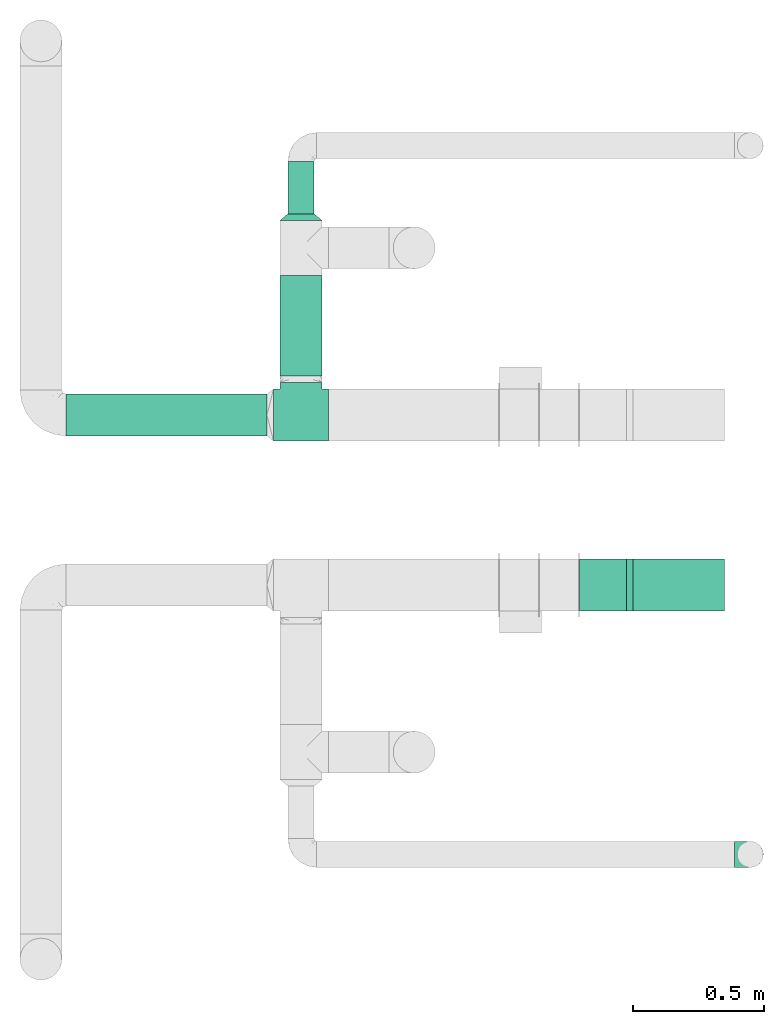
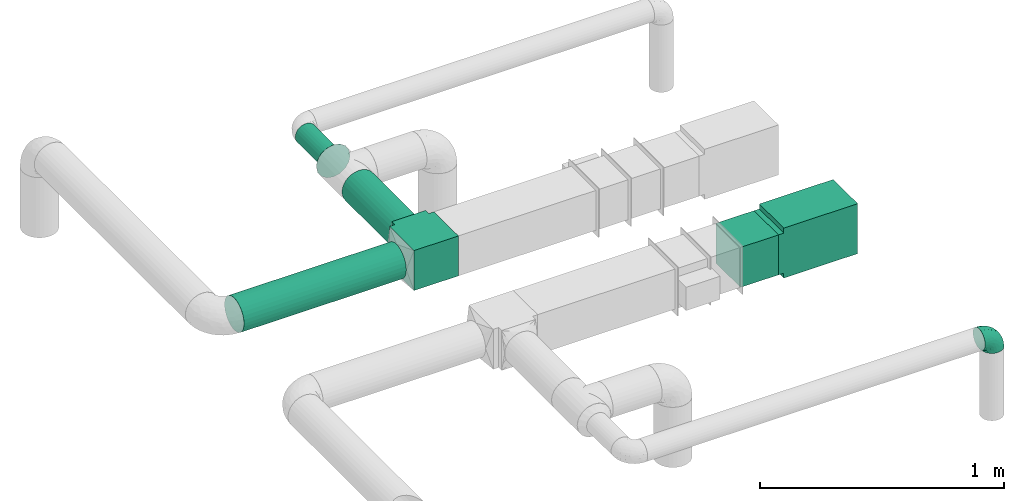
# One storey, part 6 of 12: 4 flow fittings, 4 flow segments.
"""IFC2X3 building model written with IfcOpenShell, lengths in millimetres."""

import ifcopenshell
import ifcopenshell.guid

model = None  # the IFC model being written
_history = None  # IfcOwnerHistory: only IFC2X3 demands one
_inside = {}  # id of a spatial element -> (the spatial element, [elements in it])
_under = {}  # id of a project, library or spatial element -> (it, [spatial elements below it])
_declared = {}  # id of a project -> (the project, [libraries it declares])
_typed = {}  # id of a type object -> (the type object, [elements of that type])
_made_of = {}  # id of a material, layer set ... -> (it, [elements and type objects made of it])


def new_model(schema):
    """Start an empty IFC model of exactly this schema.

    Asked for "IFC4X3", IfcOpenShell would pick the latest addendum, in which some entities
    have other attributes; the version numbers below select the first issue.
    IFC2X3 requires an IfcOwnerHistory on every rooted entity: one is made here for all.
    """
    global model, _history
    if schema == "IFC4X3":
        model = ifcopenshell.file(schema_version=(4, 3, 0, 0))
    else:
        model = ifcopenshell.file(schema=schema)
    _inside.clear()
    _under.clear()
    _declared.clear()
    _typed.clear()
    _made_of.clear()
    _history = None
    if model.schema == "IFC2X3":
        org = make("IfcOrganization", Name="unknown")
        user = make(
            "IfcPersonAndOrganization",
            ThePerson=make("IfcPerson", FamilyName="unknown"),
            TheOrganization=org,
        )
        app = make(
            "IfcApplication",
            ApplicationDeveloper=org,
            Version="unknown",
            ApplicationFullName="unknown",
            ApplicationIdentifier="unknown",
        )
        _history = make(
            "IfcOwnerHistory",
            OwningUser=user,
            OwningApplication=app,
            ChangeAction="ADDED",
            CreationDate=0,
        )
    return model


def make(cls, **values):
    """One entity of the class cls with the attributes given. An attribute that is None is left unset."""
    return model.create_entity(
        cls, **{name: value for name, value in values.items() if value is not None}
    )


def entity(cls, *values):
    """Any entity or typed value of the class cls, its attributes in the order of the schema. None: left unset."""
    e = model.create_entity(cls)
    for i, value in enumerate(values):
        if value is not None:
            e[i] = value
    return e


def rooted(cls, **values):
    """An entity with a GlobalId (a new one), such as an element, a storey or a relation."""
    return make(cls, GlobalId=ifcopenshell.guid.new(), OwnerHistory=_history, **values)


def si_unit(unit_type, name, prefix=None):
    """IfcSIUnit, for example si_unit("LENGTHUNIT", "METRE", prefix="MILLI")."""
    return make("IfcSIUnit", UnitType=unit_type, Prefix=prefix, Name=name)


def converted_unit(unit_type, name, factor, base, dimensions=None, offset=None):
    """IfcConversionBasedUnit, such as the inch: factor (a typed value) times the base unit."""
    return make(
        "IfcConversionBasedUnit"
        if offset is None
        else "IfcConversionBasedUnitWithOffset",
        ConversionOffset=offset,
        Dimensions=None
        if dimensions is None
        else entity("IfcDimensionalExponents", *dimensions),
        UnitType=unit_type,
        Name=name,
        ConversionFactor=make(
            "IfcMeasureWithUnit", ValueComponent=factor, UnitComponent=base
        ),
    )


def derived_unit(unit_type, elements):
    """IfcDerivedUnit: a product of units, each with its exponent."""
    return make(
        "IfcDerivedUnit",
        Elements=[
            make("IfcDerivedUnitElement", Unit=unit, Exponent=power)
            for unit, power in elements
        ],
        UnitType=unit_type,
    )


def assignment(units):
    """IfcUnitAssignment: the units of a project."""
    return None if units is None else make("IfcUnitAssignment", Units=units)


def point(xyz):
    """IfcCartesianPoint."""
    return None if xyz is None else make("IfcCartesianPoint", Coordinates=xyz)


def direction(xyz):
    """IfcDirection."""
    return None if xyz is None else make("IfcDirection", DirectionRatios=xyz)


def frame(location, z_axis=None, x_axis=None):
    """IfcAxis2Placement3D, a coordinate frame: its origin and axes. An axis left out is left unset."""
    return make(
        "IfcAxis2Placement3D",
        Location=point(location),
        Axis=direction(z_axis),
        RefDirection=direction(x_axis),
    )


def frame_2d(location, x_axis=None):
    """IfcAxis2Placement2D, a coordinate frame in the plane: its origin and x axis."""
    return make(
        "IfcAxis2Placement2D", Location=point(location), RefDirection=direction(x_axis)
    )


def origin():
    """The frame at (0, 0, 0) with its axes left unset."""
    return frame((0.0, 0.0, 0.0))


def origin_2d_with_axis():
    """The frame at (0, 0) in the plane with the x axis (1, 0) written out."""
    return frame_2d((0.0, 0.0), x_axis=(1.0, 0.0))


def place(relative_to, where):
    """IfcLocalPlacement: puts the frame where relative to a parent placement (None: the world)."""
    return make(
        "IfcLocalPlacement", PlacementRelTo=relative_to, RelativePlacement=where
    )


def context(
    kind, dimensions, precision=None, world=None, true_north=None, identifier=None
):
    """IfcGeometricRepresentationContext, for example the 3D "Model" context."""
    return make(
        "IfcGeometricRepresentationContext",
        ContextIdentifier=identifier,
        ContextType=kind,
        CoordinateSpaceDimension=dimensions,
        Precision=precision,
        WorldCoordinateSystem=world,
        TrueNorth=true_north,
    )


def subcontext(parent, identifier, kind, view, scale=None):
    """IfcGeometricRepresentationSubContext, for example "Body" below "Model"."""
    return make(
        "IfcGeometricRepresentationSubContext",
        ContextIdentifier=identifier,
        ContextType=kind,
        ParentContext=parent,
        TargetScale=scale,
        TargetView=view,
    )


def project(units=None, contexts=None):
    """IfcProject with its units and contexts."""
    return rooted(
        "IfcProject",
        Name="project",
        RepresentationContexts=contexts,
        UnitsInContext=assignment(units),
    )


def spatial(cls, under=None, at=None, **own):
    """A site, building, storey or space (cls), placed at a placement, below another one or the project."""
    s = rooted(cls, ObjectPlacement=at, **own)
    if under is not None:
        _under.setdefault(under.id(), (under, []))[1].append(s)
    return s


def polyline(points):
    """IfcPolyline through the points."""
    return make("IfcPolyline", Points=[point(p) for p in points])


def profile(cls, at=None, kind="AREA", **sizes):
    """A parametric profile (cls). Its sizes go by their IFC names, for example OverallWidth=200.0."""
    return make(cls, ProfileType=kind, Position=at, **sizes)


def rectangle(**sizes):
    """IfcRectangleProfileDef."""
    return profile("IfcRectangleProfileDef", **sizes)


def circle(**sizes):
    """IfcCircleProfileDef."""
    return profile("IfcCircleProfileDef", **sizes)


def outline(outer, holes=None, kind="AREA"):
    """IfcArbitraryClosedProfileDef: a profile drawn as a closed curve; with holes, ...WithVoids."""
    if holes is None:
        return make("IfcArbitraryClosedProfileDef", ProfileType=kind, OuterCurve=outer)
    return make(
        "IfcArbitraryProfileDefWithVoids",
        ProfileType=kind,
        OuterCurve=outer,
        InnerCurves=holes,
    )


def extrude(swept, where, along, depth):
    """IfcExtrudedAreaSolid: the profile swept, set in the frame where, extruded along a direction by depth."""
    return make(
        "IfcExtrudedAreaSolid",
        SweptArea=swept,
        Position=where,
        ExtrudedDirection=direction(along),
        Depth=depth,
    )


def faces_of(points, faces, orient=None, outer=None):
    """IfcFace entities. A face is a list of loops; a loop is a list of indices into points, from 0.

    orient and outer hold one flag for each loop. By default every Orientation is true, the
    first loop of a face is its IfcFaceOuterBound and the others are IfcFaceBound.
    """
    made = []
    for i, loops in enumerate(faces):
        bounds = []
        for j, loop in enumerate(loops):
            is_outer = j == 0 if outer is None else outer[i][j]
            bounds.append(
                make(
                    "IfcFaceOuterBound" if is_outer else "IfcFaceBound",
                    Bound=make("IfcPolyLoop", Polygon=[points[k] for k in loop]),
                    Orientation=True if orient is None else orient[i][j],
                )
            )
        made.append(make("IfcFace", Bounds=bounds))
    return made


def faceted_brep(points, faces, orient=None, outer=None, voids=None):
    """IfcFacetedBrep: a solid bounded by flat faces; with voids (closed shells), ...WithVoids."""
    shared = [point(p) for p in points]
    hull = make("IfcClosedShell", CfsFaces=faces_of(shared, faces, orient, outer))
    if voids is None:
        return make("IfcFacetedBrep", Outer=hull)
    return make(
        "IfcFacetedBrepWithVoids",
        Outer=hull,
        Voids=[
            make(cls, CfsFaces=faces_of(shared, fs, o, b)) for cls, fs, o, b in voids
        ],
    )


def shape(context_of_items, identifier, shape_type, items):
    """IfcShapeRepresentation: the items that make up one representation, for example the "Body"."""
    return make(
        "IfcShapeRepresentation",
        ContextOfItems=context_of_items,
        RepresentationIdentifier=identifier,
        RepresentationType=shape_type,
        Items=items,
    )


def source(mapping_origin, context_of_items, identifier, shape_type, items):
    """IfcRepresentationMap: a shape defined once, which mapped items show again and again."""
    return make(
        "IfcRepresentationMap",
        MappingOrigin=mapping_origin,
        MappedRepresentation=shape(context_of_items, identifier, shape_type, items),
    )


def transform(
    local_origin,
    x_axis=None,
    y_axis=None,
    z_axis=None,
    scale=None,
    scale2=None,
    scale3=None,
    uniform=True,
):
    """IfcCartesianTransformationOperator3D, or its non-uniform kind. x_axis, y_axis, z_axis: its Axis1, 2, 3."""
    if uniform:
        return make(
            "IfcCartesianTransformationOperator3D",
            Axis1=direction(x_axis),
            Axis2=direction(y_axis),
            LocalOrigin=point(local_origin),
            Scale=scale,
            Axis3=direction(z_axis),
        )
    return make(
        "IfcCartesianTransformationOperator3DnonUniform",
        Axis1=direction(x_axis),
        Axis2=direction(y_axis),
        LocalOrigin=point(local_origin),
        Scale=scale,
        Axis3=direction(z_axis),
        Scale2=scale2,
        Scale3=scale3,
    )


def mapped(mapping_source, mapping_target):
    """IfcMappedItem: shows the shape of a source again, moved by a transform."""
    return make(
        "IfcMappedItem", MappingSource=mapping_source, MappingTarget=mapping_target
    )


def material(Name=None, Category=None):
    """IfcMaterial."""
    return make("IfcMaterial", Name=Name, Category=Category)


def made_of(thing, what):
    """Note that an element or type object is made of a material, layer set ...; save() writes the relation."""
    if what is not None:
        _made_of.setdefault(what.id(), (what, []))[1].append(thing)
    return thing


def type_object(cls, material=None, **own):
    """A type object (cls), such as IfcWallType, which elements share."""
    return made_of(rooted(cls, **own), material)


def type_shapes(of_type, sources):
    """Give a type object the sources (RepresentationMaps) that its elements show as mapped items."""
    of_type.RepresentationMaps = sources


def element(
    cls,
    number,
    at=None,
    inside=None,
    cuts=None,
    type_object=None,
    material=None,
    context=None,
    identifier="Body",
    shape_type=None,
    held_by="IfcProductDefinitionShape",
    body=None,
    shapes=None,
    **own,
):
    """One element of the class cls, such as IfcWall. Its Tag is "e" and its number.

    at: its placement. inside: the storey or other place that contains it. cuts: it is an
    opening in that element (IfcRelVoidsElement). A single representation is given by context,
    identifier, shape_type and body (its items); several are given by shapes. held_by: the class
    of the entity that holds the representations. save() writes the other relations.
    """
    e = rooted(cls, Tag="e%d" % number, ObjectPlacement=at, **own)
    if body is not None:
        shapes = [shape(context, identifier, shape_type, body)]
    if shapes is not None:
        e.Representation = make(held_by, Representations=shapes)
    if inside is not None:
        _inside.setdefault(inside.id(), (inside, []))[1].append(e)
    if cuts is not None:
        rooted(
            "IfcRelVoidsElement", RelatingBuildingElement=cuts, RelatedOpeningElement=e
        )
    if type_object is not None:
        _typed.setdefault(type_object.id(), (type_object, []))[1].append(e)
    return made_of(e, material)


def aggregate(whole, parts):
    """IfcRelAggregates: a whole, such as a stair, and the parts it consists of."""
    return rooted("IfcRelAggregates", RelatingObject=whole, RelatedObjects=parts)


def save(model, path):
    """Write the relations noted so far, then the file.

    IfcRelAggregates (storeys below a building ...), IfcRelContainedInSpatialStructure (elements
    in a storey), IfcRelDefinesByType, IfcRelAssociatesMaterial and IfcRelDeclares: one each for
    every whole, place, type object, material and project.
    """
    for whole, parts in _under.values():
        aggregate(whole, parts)
    for where, things in _inside.values():
        rooted(
            "IfcRelContainedInSpatialStructure",
            RelatedElements=things,
            RelatingStructure=where,
        )
    for kind, things in _typed.values():
        rooted("IfcRelDefinesByType", RelatedObjects=things, RelatingType=kind)
    for what, things in _made_of.values():
        rooted("IfcRelAssociatesMaterial", RelatedObjects=things, RelatingMaterial=what)
    for by, libraries in _declared.values():
        rooted("IfcRelDeclares", RelatingContext=by, RelatedDefinitions=libraries)
    model.write(path)


model = new_model("IFC2X3")

# Units and contexts
model_context = context("Model", 3, precision=0.01, world=origin(), true_north=direction((6.12303176911189e-17, 1.0)))
body_context = subcontext(model_context, "Body", "Model", "MODEL_VIEW")
ifc_project = project(units=[si_unit("LENGTHUNIT", "METRE", prefix="MILLI"), si_unit("AREAUNIT", "SQUARE_METRE"), si_unit("VOLUMEUNIT", "CUBIC_METRE"), converted_unit("PLANEANGLEUNIT", "DEGREE", entity("IfcRatioMeasure", 0.0174532925199433), si_unit("PLANEANGLEUNIT", "RADIAN"), dimensions=[0, 0, 0, 0, 0, 0, 0]), si_unit("MASSUNIT", "GRAM", prefix="KILO"), derived_unit("MASSDENSITYUNIT", [(si_unit("MASSUNIT", "GRAM", prefix="KILO"), 1), (si_unit("LENGTHUNIT", "METRE"), -3)]), si_unit("TIMEUNIT", "SECOND"), si_unit("FREQUENCYUNIT", "HERTZ"), si_unit("THERMODYNAMICTEMPERATUREUNIT", "DEGREE_CELSIUS"), derived_unit("THERMALTRANSMITTANCEUNIT", [(si_unit("MASSUNIT", "GRAM", prefix="KILO"), 1), (si_unit("THERMODYNAMICTEMPERATUREUNIT", "KELVIN"), -1), (si_unit("TIMEUNIT", "SECOND"), -3)]), derived_unit("VOLUMETRICFLOWRATEUNIT", [(si_unit("LENGTHUNIT", "METRE"), 3), (si_unit("TIMEUNIT", "SECOND"), -1)]), si_unit("ELECTRICCURRENTUNIT", "AMPERE"), si_unit("ELECTRICVOLTAGEUNIT", "VOLT"), si_unit("POWERUNIT", "WATT"), si_unit("FORCEUNIT", "NEWTON", prefix="KILO"), si_unit("ILLUMINANCEUNIT", "LUX"), si_unit("LUMINOUSFLUXUNIT", "LUMEN"), si_unit("LUMINOUSINTENSITYUNIT", "CANDELA"), derived_unit("USERDEFINED", [(si_unit("MASSUNIT", "GRAM", prefix="KILO"), -1), (si_unit("LENGTHUNIT", "METRE"), -2), (si_unit("TIMEUNIT", "SECOND"), 3), (si_unit("LUMINOUSFLUXUNIT", "LUMEN"), 1)]), derived_unit("LINEARVELOCITYUNIT", [(si_unit("LENGTHUNIT", "METRE"), 1), (si_unit("TIMEUNIT", "SECOND"), -1)]), si_unit("PRESSUREUNIT", "PASCAL"), derived_unit("USERDEFINED", [(si_unit("LENGTHUNIT", "METRE"), -2), (si_unit("MASSUNIT", "GRAM", prefix="KILO"), 1), (si_unit("TIMEUNIT", "SECOND"), -2)])], contexts=[model_context])

# Site, building, storey
site_placement = place(None, origin())
site = spatial("IfcSite", under=ifc_project, at=site_placement, CompositionType="ELEMENT")
building_placement = place(site_placement, origin())
building = spatial("IfcBuilding", under=site, at=building_placement, CompositionType="ELEMENT")
storey_placement = place(building_placement, frame((0.0, 0.0, 8000.0)))
storey = spatial("IfcBuildingStorey", under=building, at=storey_placement, Name="02 Level", CompositionType="ELEMENT", Elevation=8000.0)

# Flow segments
duct_segment_type_1 = type_object("IfcDuctSegmentType", Name="Round Duct:Air", PredefinedType="NOTDEFINED")
flow_segment_1_placement = place(storey_placement, frame((22287.748982204, -68588.0392131986, 2918.40472776409)))
element("IfcFlowSegment", 1, at=flow_segment_1_placement, inside=storey, type_object=duct_segment_type_1, Name="Round Duct:Air", ObjectType="Round Duct:Air", context=body_context, shape_type="SweptSolid", body=[
    extrude(circle(Radius=80.0, at=origin_2d_with_axis()), frame((0.0, 81.5952722359237, 81.595272235915), z_axis=(1.0, 0.0, 0.0), x_axis=(0.0, -1.0, 0.0)), (0.0, 0.0, 1.0), 768.241088647822),
])
flow_segment_2_placement = place(storey_placement, frame((23134.3947986159, -67737.2449387878, 2948.40472776403)))
element("IfcFlowSegment", 2, at=flow_segment_2_placement, inside=storey, type_object=duct_segment_type_1, Name="Round Duct:Air", ObjectType="Round Duct:Air", context=body_context, shape_type="SweptSolid", body=[
    extrude(circle(Radius=50.0, at=origin_2d_with_axis()), frame((51.5952722359175, 0.0, 51.5952722359154), z_axis=(0.0, 1.0, 0.0), x_axis=(-1.0, 0.0, 0.0)), (0.0, 0.0, 1.0), 200.701380999497),
])
flow_segment_3_placement = place(storey_placement, frame((23104.3947986159, -68356.4439409626, 2918.40472776409)))
element("IfcFlowSegment", 3, at=flow_segment_3_placement, inside=storey, type_object=duct_segment_type_1, Name="Round Duct:Air", ObjectType="Round Duct:Air", context=body_context, shape_type="SweptSolid", body=[
    extrude(circle(Radius=80.0, at=origin_2d_with_axis()), frame((81.595272235915, 0.0, 81.5952722359129), z_axis=(0.0, 1.0, 0.0), x_axis=(-1.0, 0.0, 0.0)), (0.0, 0.0, 1.0), 384.199002174792),
])

# Flow fitting
duct_fitting_type_1 = type_object("IfcDuctFittingType", Name="Air_Elbow short_Circ", PredefinedType="NOTDEFINED")
shared_shape_1 = source(origin(), body_context, "Body", "Brep", [
    faceted_brep([(-60.0, 0.0, -50.0), (-60.0, -12.9409522551259, -48.2962913144534), (-60.0, -25.0, -43.3012701892219), (-60.0, -35.3553390593273, -35.3553390593274), (-60.0, -43.3012701892218, -25.0), (-60.0, -48.2962913144533, -12.9409522551262), (-60.0, -50.0, 0.0), (-60.0, -48.2962913144534, 12.9409522551259), (-60.0, -43.301270189222, 25.0), (-60.0, -35.3553390593275, 35.3553390593272), (-60.0, -25.0, 43.3012701892218), (-60.0, -12.9409522551262, 48.2962913144533), (-60.0, 0.0, 50.0), (-60.0, 12.9409522551258, 48.2962913144534), (-60.0, 18.9704761275628, 45.7987807518377), (-60.0, 25.0, 43.301270189222), (-60.0, 35.3553390593271, 35.3553390593275), (-60.0, 43.3012701892217, 25.0), (-60.0, 48.2962913144533, 12.9409522551263), (-60.0, 50.0, 0.0), (-60.0, 48.2962913144534, -12.940952255126), (-60.0, 43.3012701892219, -25.0), (-60.0, 35.3553390593274, -35.3553390593273), (-60.0, 25.0, -43.3012701892219), (-60.0, 12.9409522551261, -48.2962913144533), (-12.9409522551252, 60.0, -48.2962913144533), (-18.9704761275622, 60.0, -45.7987807518376), (-25.0, 60.0, -43.3012701892219), (-35.3553390593265, 60.0, -35.3553390593273), (-43.301270189221, 60.0, -25.0), (-48.2962913144525, 60.0, -12.940952255126), (-50.0, 60.0, 0.0), (-48.2962913144524, 60.0, 12.9409522551263), (-43.3012701892209, 60.0, 25.0), (-35.3553390593263, 60.0, 35.3553390593275), (-25.0, 60.0, 43.301270189222), (-12.9409522551249, 60.0, 48.2962913144534), (0.0, 60.0, 50.0), (12.9409522551271, 60.0, 48.2962913144533), (25.0, 60.0, 43.3012701892218), (35.3553390593284, 60.0, 35.3553390593272), (43.3012701892229, 60.0, 25.0), (48.2962913144543, 60.0, 12.9409522551259), (50.0, 60.0, 0.0), (48.2962913144542, 60.0, -12.9409522551262), (43.3012701892227, 60.0, -25.0), (35.3553390593281, 60.0, -35.3553390593274), (25.0, 60.0, -43.3012701892219), (12.9409522551268, 60.0, -48.2962913144534), (0.0, 60.0, -50.0), (-49.0564079906538, -40.7801415025898, 28.076858272246), (-41.7413930879589, -46.3367006663211, 14.3622192349088), (-34.4613055182162, -40.2781615499549, 24.6893391361235), (-43.0040653093767, -47.3081083962334, 0.0), (-49.945230570524, 14.009456366224, 48.3010541644054), (-46.9531334224505, 28.9691372331723, 42.5007483631415), (46.3367008388525, 41.7413924405609, 14.3622183025403), (-20.8886043148544, -37.032907476011, 22.5646988156665), (-16.4026032888538, -28.8335615486346, 31.3447155376829), (-28.9195822317624, -34.3595042325614, 30.8522337271345), (18.1051423029501, 18.6630708487668, 41.1725129713058), (21.5851347328685, 39.3600400603544, 43.7780030266717), (8.51327307359233, 29.8490270681828, 47.7425705251578), (-16.993357552601, 43.112835299455, 48.0588376259554), (-3.94145017646366, 44.1513377558611, 49.9695692624666), (-39.360041631582, -21.585137213725, 43.7780019122438), (-18.6630773197735, -18.1051465687322, 41.1725124591201), (-29.8490305613342, -8.51327565171467, 47.7425702287428), (-41.9572959526986, -32.3456520264411, 36.575294220854), (-28.3738768436699, -26.9110252548877, 38.0083212356069), (-51.9080682539527, 51.9080682564403, 11.9284381035673), (-47.8035915916317, 49.3365848090307, 24.1167211667097), (-28.9388870718402, 47.4392187660381, 42.4028289139121), (-46.4119732313288, -8.97786791845547, 48.9268647037242), (-0.0901680697707372, -16.249793899354, 33.6631038709893), (12.7026747916207, -16.0653579926251, 21.330563165355), (15.3655862372502, -1.44443599762982, 33.3656926605527), (-40.3512409746586, 17.2001159603688, 48.3058104561749), (-43.5357165770215, 3.92607608695299, 49.9756911723036), (-26.0984306641832, 9.4519602521943, 49.9925353018775), (-51.5116032222349, 38.9116886125261, 33.3337470302399), (32.3456522233896, 41.9572963751397, 36.5752941161915), (34.3595052098631, 28.9195768148052, 30.852230382061), (40.2781623134548, 34.4613024546835, 24.689336501659), (-52.6192947824697, 44.3162483434043, 26.0687788699409), (8.97786691245749, 46.4119718726044, 48.9268648562795), (35.0507691245895, 17.8379542600364, 23.7817320689175), (-10.9191638901366, -35.9593562872322, 14.7243484546897), (0.164802122834046, -30.9507973718637, 9.70158150296541), (-0.154113830211583, -27.0441585303382, 20.4371969134619), (40.7801421145919, 49.0564069362065, 28.0768572079665), (42.5446020921407, 25.3772134428819, 13.1791087429088), (10.303795037543, -23.1674391280597, 10.425151792526), (23.1044280783399, -10.2139010010231, 10.911201952746), (44.6162167924678, 26.008130618756, 0.0), (47.3081083962343, 43.0040653093781, 0.0), (-41.6246972537655, 41.624696659769, 36.6481760707585), (-32.7984308187714, 33.1644722725009, 45.0025999357929), (-7.74597844975689, 15.8760781607658, 49.2907901610601), (-16.0198594588589, 0.790040969679908, 48.0702532559686), (-10.2505184648613, 32.0701285913551, 49.9130990257927), (-52.9289321881336, 52.9289321881345, 0.0), (-38.9116885130941, 51.5116028691678, 33.3337472807585), (28.8335585354312, 16.4025932897411, 31.3447134244473), (27.3373523634918, 28.9262874076833, 37.8242669720924), (-10.6758764332908, -36.8040430868554, 0.0), (-21.0820556464647, 25.013405385062, 49.4085637061446), (-25.3772163464242, -42.5446022063287, 13.179111746218), (-29.4708300504911, 18.1716321771538, 49.3204506255928), (-0.613576836584022, 32.0726800049485, 49.6825501479137), (-26.0081306187546, -44.6162167924668, 0.0), (7.809323786389, 12.5506490133832, 44.518448707346), (-1.21981718883359, 1.21981162112378, 44.3295369128094), (4.65637775217312, -28.991869381244, 0.0), (25.4694098156993, -0.899564345657441, 21.9045256717261), (30.9271083665945, -0.192011278925337, 9.72551394481069), (36.8040430868565, 10.6758764332921, 0.0), (8.17237141004653, 0.709602060124845, 39.7363553078916), (-1.20691178924098, -8.42774890414073, 39.8368437988478), (-11.8311378719951, -8.12805454147699, 44.1670059112514), (16.8241235667092, -16.8241235667079, 0.0), (35.9593546638031, 10.9191599029529, 14.7243472530362), (28.9918693812452, -4.65637775217184, 0.0), (-14.0094588862512, 49.9452236085703, -48.3010539035587), (-41.7413926252934, -46.3367005832334, -14.3622192468898), (-34.4613048910139, -40.2781614393135, -24.6893390523416), (-25.3772156484835, -42.5446019119684, -13.1791119497906), (-43.1128355702084, 16.9933564311214, -48.0588378972243), (-44.1513388294639, 3.94144876101963, -49.969569299814), (-49.3365851024771, 47.8035917204495, -24.1167206397972), (-41.62469790636, 41.6246960630329, -36.6481760341003), (-51.5116035577561, 38.9116884747343, -33.3337470330805), (23.1674375203698, -10.3037953844737, -10.4251565011195), (10.2138986720569, -23.1044286164337, -10.9112068363266), (16.0653446591387, -12.7026862735946, -21.330566780897), (35.9593546209329, 10.9191616413996, -14.7243499458666), (30.9507965291521, -0.164803474452689, -9.70158128624016), (27.0441512446144, 0.154114142874967, -20.4372107139949), (-18.6630757642047, -18.1051470727615, -41.1725116507822), (-16.4026019873643, -28.8335613017021, -31.344715100551), (-28.9262923378956, -27.3373567288812, -37.8242648451571), (-15.8760743141415, 7.74597807562093, -49.2907896898935), (-9.45196719952168, 26.0984311316614, -49.9925354060889), (-0.79004904716724, 16.0198534732482, -48.0702540902608), (-25.0134056140136, 21.0820528609103, -49.4085640038716), (-49.0564077792961, -40.7801415002595, -28.0768582420378), (-47.4392196421628, 28.9388866268174, -42.4028289664685), (-33.1644687800828, 32.7984277324913, -45.0026021871039), (-51.9080682748156, 51.9080682458111, -11.9284380741106), (-41.9572952892088, -32.3456521258773, -36.5752940113004), (-39.3600407942016, -21.5851376014369, -43.7780015915287), (-29.8490289400598, -8.5132766456386, -47.7425697425162), (-46.411972568153, -8.97786849540185, -48.9268645575236), (-28.9195813138317, -34.3595041939927, -30.8522334076151), (-17.8379596675892, -35.0507702162708, -23.7817342784206), (21.5851368100191, 39.3600388626355, -43.7780017534797), (26.9110256448416, 28.3738769796432, -38.0083209621406), (18.1051443153088, 18.6630730295509, -41.1725124486671), (-38.911688364674, 51.5116023985273, -33.3337476311683), (-44.316248159738, 52.6192941440622, -26.0687795868405), (-17.2001201011705, 40.3512365316697, -48.3058099460363), (-3.92607321834031, 43.5357049838062, -49.9756913600445), (8.51327412363391, 29.8490256018375, -47.7425700423665), (8.97786798225732, 46.4119703958823, -48.9268645751331), (40.7801413413476, 49.0564079294803, -28.0768584987253), (-28.969136268001, 46.9531365639949, -42.5007481599507), (16.2497893015437, 0.0901603719773552, -33.6631026184802), (1.44442453081588, -15.3655954628303, -33.3656927670723), (32.3456517066656, 41.9572939682546, -36.5752941586943), (46.3367004266908, 41.7413922128929, -14.3622195286513), (34.3595039081184, 28.9195810717321, -30.8522336573022), (37.0329066484517, 20.888602858321, -22.564699256686), (28.8335602968518, 16.402602640196, -31.3447165791004), (40.2781610753798, 34.461304879185, -24.6893396682814), (-32.0701289123428, 10.2505155181949, -49.9130991682027), (42.5446013435109, 25.3772148558883, -13.1791129929581), (-18.17163862849, 29.4708285244359, -49.3204499074468), (-32.0726819537407, 0.61357350659226, -49.6825499006192), (-12.5506417422758, -7.80933382246174, -44.5184423716321), (-1.21981337419447, 1.21981084831843, -44.3295352204376), (0.899550937376629, -25.4694163362272, -21.9045307406697), (0.192009591001318, -30.9271092740971, -9.72551482732434), (-0.709596078235449, -8.17237239935393, -39.7363517396473), (8.42775025848031, 1.2069144200305, -39.8368443201002), (8.12805004108825, 11.8311369938791, -44.1670075921659), (-10.9191629014402, -35.9593557213529, -14.724348628576)], [[[0, 1, 2, 3, 4, 5, 6, 7, 8, 9, 10, 11, 12, 13, 14, 15, 16, 17, 18, 19, 20, 21, 22, 23, 24]], [[25, 26, 27, 28, 29, 30, 31, 32, 33, 34, 35, 36, 37, 38, 39, 40, 41, 42, 43, 44, 45, 46, 47, 48, 49]], [[50, 51, 52]], [[53, 7, 6]], [[54, 55, 15]], [[41, 56, 42]], [[57, 58, 59]], [[60, 61, 62]], [[36, 63, 64]], [[65, 66, 67]], [[10, 68, 65]], [[59, 69, 68]], [[70, 71, 32]], [[9, 8, 50]], [[35, 72, 63]], [[12, 11, 73]], [[74, 75, 76]], [[15, 14, 13, 54]], [[77, 78, 79]], [[11, 10, 65]], [[51, 8, 7]], [[16, 80, 17]], [[81, 82, 83]], [[80, 84, 17]], [[15, 55, 16]], [[35, 34, 72]], [[18, 70, 19]], [[65, 67, 73]], [[38, 37, 85]], [[84, 18, 17]], [[61, 38, 85]], [[82, 86, 83]], [[87, 88, 89]], [[38, 61, 39]], [[40, 90, 41]], [[64, 37, 36]], [[56, 83, 91]], [[56, 41, 90]], [[61, 81, 39]], [[92, 93, 75]], [[56, 94, 95]], [[72, 96, 97]], [[98, 79, 99]], [[100, 64, 63]], [[101, 19, 70]], [[10, 9, 68]], [[101, 70, 31]], [[65, 69, 66]], [[96, 102, 71]], [[60, 103, 104]], [[33, 102, 34]], [[88, 87, 105]], [[33, 32, 71]], [[63, 72, 97]], [[98, 106, 79]], [[36, 35, 63]], [[13, 12, 78]], [[107, 87, 57]], [[81, 40, 39]], [[83, 86, 91]], [[7, 53, 51]], [[95, 42, 56]], [[73, 78, 12]], [[108, 79, 106]], [[77, 108, 97]], [[80, 55, 96]], [[102, 72, 34]], [[96, 55, 97]], [[100, 63, 106]], [[64, 109, 85]], [[104, 81, 61]], [[90, 81, 83]], [[50, 68, 9]], [[59, 68, 52]], [[78, 67, 79]], [[110, 51, 53]], [[43, 42, 95]], [[99, 79, 67]], [[111, 98, 112]], [[100, 109, 64]], [[52, 51, 107]], [[88, 113, 92]], [[114, 93, 115]], [[103, 60, 76]], [[103, 76, 114]], [[116, 94, 91]], [[112, 117, 111]], [[76, 75, 114]], [[112, 118, 117]], [[119, 118, 112]], [[74, 66, 58]], [[99, 119, 112]], [[74, 58, 89]], [[76, 117, 118]], [[77, 97, 55]], [[63, 97, 106]], [[92, 113, 120]], [[114, 121, 86]], [[115, 93, 122]], [[122, 93, 120]], [[75, 93, 114]], [[93, 92, 120]], [[92, 75, 89]], [[74, 89, 75]], [[57, 89, 58]], [[64, 85, 37]], [[61, 85, 62]], [[65, 73, 11]], [[78, 73, 67]], [[51, 110, 107]], [[115, 116, 121]], [[91, 121, 116]], [[94, 56, 91]], [[71, 102, 33]], [[72, 102, 96]], [[55, 80, 16]], [[84, 96, 71]], [[106, 98, 100]], [[109, 98, 62]], [[98, 109, 100]], [[85, 109, 62]], [[89, 88, 92]], [[107, 105, 87]], [[96, 84, 80]], [[84, 71, 70]], [[70, 18, 84]], [[31, 70, 32]], [[51, 50, 8]], [[68, 50, 52]], [[81, 90, 40]], [[56, 90, 83]], [[54, 78, 77]], [[78, 54, 13]], [[54, 77, 55]], [[60, 104, 61]], [[82, 104, 103]], [[104, 82, 81]], [[86, 82, 103]], [[114, 86, 103]], [[86, 121, 91]], [[57, 59, 52]], [[69, 59, 58]], [[66, 69, 58]], [[68, 69, 65]], [[107, 57, 52]], [[57, 87, 89]], [[97, 108, 106]], [[77, 79, 108]], [[119, 67, 66]], [[98, 99, 112]], [[67, 119, 99]], [[118, 66, 74]], [[66, 118, 119]], [[76, 118, 74]], [[76, 60, 117]], [[111, 117, 60]], [[60, 62, 111]], [[98, 111, 62]], [[105, 107, 110]], [[113, 88, 105]], [[116, 115, 122]], [[114, 115, 121]], [[123, 27, 26, 25]], [[124, 125, 126]], [[23, 127, 24]], [[0, 24, 128]], [[129, 130, 131]], [[132, 133, 134]], [[21, 131, 22]], [[135, 136, 137]], [[21, 20, 129]], [[138, 139, 140]], [[141, 142, 143]], [[144, 142, 141]], [[124, 4, 145]], [[146, 130, 147]], [[124, 110, 53]], [[148, 129, 20]], [[149, 2, 150]], [[138, 150, 151]], [[1, 150, 2]], [[127, 146, 147]], [[23, 22, 146]], [[145, 4, 3]], [[3, 2, 149]], [[1, 152, 150]], [[153, 154, 125]], [[149, 153, 125]], [[19, 101, 148]], [[125, 154, 126]], [[31, 30, 148]], [[155, 156, 157]], [[29, 158, 159]], [[48, 47, 155]], [[136, 135, 116]], [[28, 158, 29]], [[146, 127, 23]], [[160, 161, 142]], [[155, 162, 163]], [[46, 45, 164]], [[28, 27, 165]], [[166, 134, 167]], [[48, 163, 49]], [[168, 155, 47]], [[24, 127, 128]], [[169, 45, 44]], [[170, 171, 172]], [[162, 155, 157]], [[1, 0, 152]], [[173, 164, 169]], [[25, 49, 161]], [[43, 95, 44]], [[47, 46, 168]], [[174, 128, 127]], [[170, 156, 168]], [[123, 165, 27]], [[4, 124, 5]], [[44, 95, 169]], [[148, 20, 19]], [[175, 135, 171]], [[159, 30, 29]], [[53, 5, 124]], [[163, 161, 49]], [[176, 142, 144]], [[160, 176, 147]], [[158, 165, 130]], [[131, 146, 22]], [[130, 165, 147]], [[174, 127, 144]], [[128, 177, 152]], [[140, 149, 150]], [[145, 149, 125]], [[164, 168, 46]], [[170, 168, 173]], [[161, 162, 142]], [[94, 169, 95]], [[6, 5, 53]], [[143, 142, 162]], [[178, 141, 179]], [[174, 177, 128]], [[173, 169, 175]], [[136, 122, 132]], [[180, 133, 181]], [[139, 138, 167]], [[139, 167, 180]], [[105, 110, 126]], [[179, 182, 178]], [[167, 134, 180]], [[179, 183, 182]], [[184, 183, 179]], [[166, 157, 172]], [[143, 184, 179]], [[166, 172, 137]], [[167, 182, 183]], [[160, 147, 165]], [[127, 147, 144]], [[132, 122, 120]], [[180, 185, 154]], [[181, 133, 113]], [[113, 133, 120]], [[134, 133, 180]], [[133, 132, 120]], [[132, 134, 137]], [[166, 137, 134]], [[171, 137, 172]], [[128, 152, 0]], [[150, 152, 151]], [[155, 163, 48]], [[161, 163, 162]], [[169, 94, 175]], [[181, 105, 185]], [[126, 185, 105]], [[110, 124, 126]], [[129, 131, 21]], [[146, 131, 130]], [[165, 158, 28]], [[159, 130, 129]], [[144, 141, 174]], [[177, 141, 151]], [[141, 177, 174]], [[152, 177, 151]], [[137, 136, 132]], [[175, 116, 135]], [[130, 159, 158]], [[159, 129, 148]], [[31, 148, 101]], [[148, 30, 159]], [[169, 164, 45]], [[168, 164, 173]], [[149, 145, 3]], [[124, 145, 125]], [[123, 161, 160]], [[161, 123, 25]], [[123, 160, 165]], [[138, 140, 150]], [[153, 140, 139]], [[140, 153, 149]], [[154, 153, 139]], [[180, 154, 139]], [[154, 185, 126]], [[171, 170, 173]], [[156, 170, 172]], [[157, 156, 172]], [[168, 156, 155]], [[175, 171, 173]], [[171, 135, 137]], [[147, 176, 144]], [[160, 142, 176]], [[184, 162, 157]], [[141, 143, 179]], [[162, 184, 143]], [[183, 157, 166]], [[157, 183, 184]], [[167, 183, 166]], [[167, 138, 182]], [[178, 182, 138]], [[138, 151, 178]], [[141, 178, 151]], [[116, 175, 94]], [[122, 136, 116]], [[105, 181, 113]], [[180, 181, 185]]]),
])
type_shapes(duct_fitting_type_1, [shared_shape_1])
flow_fitting_1_placement = place(storey_placement, frame((24903.4900708518, -70185.9356124915, 3000.0), z_axis=(0.0, -1.0, 0.0), x_axis=(0.0, 0.0, 1.0)))
element("IfcFlowFitting", 4, at=flow_fitting_1_placement, inside=storey, type_object=duct_fitting_type_1, Name="elbow_short_001:Air_Elbow short_Circ", ObjectType="elbow_short_001:Air_Elbow short_Circ", context=body_context, shape_type="MappedRepresentation", body=[
    mapped(shared_shape_1, transform((0.0, 0.0, 0.0), scale=1.0)),
])

# Flow segment
duct_segment_type_2 = type_object("IfcDuctSegmentType", Name="Rectangular Duct:Air", PredefinedType="NOTDEFINED")
flow_segment_4_placement = place(storey_placement, frame((24250.9900708518, -69256.0352293172, 2900.0)))
element("IfcFlowSegment", 5, at=flow_segment_4_placement, inside=storey, type_object=duct_segment_type_2, Name="Rectangular Duct:Air", ObjectType="Rectangular Duct:Air", context=body_context, shape_type="SweptSolid", body=[
    extrude(rectangle(XDim=179.671447124557, YDim=199.999999999998, at=frame_2d((0.0, -4.33431068813661e-12), x_axis=(1.0, 0.0))), frame((89.8357235622787, 100.0, 0.0)), (0.0, 0.0, 1.0), 200.000000000002),
])

# Flow fittings
duct_fitting_type_2 = type_object("IfcDuctFittingType", Name="Air_Rect", PredefinedType="NOTDEFINED")
shared_shape_2 = source(origin(), body_context, "Body", "SweptSolid", [
    extrude(outline(polyline([(-125.0, 81.25), (-125.0, -268.75), (125.0, -268.75), (125.0, 81.2500000000001), (100.0, 81.2500000000001), (100.0, 106.25), (-100.0, 106.25), (-100.0, 81.25), (-125.0, 81.25)])), frame((0.0, -93.75, -100.0), z_axis=(0.0, 0.0, -1.0), x_axis=(1.0, 0.0, 0.0)), (0.0, 0.0, -1.0), 200.0),
])
type_shapes(duct_fitting_type_2, [shared_shape_2])
flow_fitting_2_placement = place(storey_placement, frame((24630.6615179764, -69156.0352293172, 3000.0), z_axis=(0.0, -1.0, 0.0), x_axis=(0.0, 0.0, -1.0)))
element("IfcFlowFitting", 6, at=flow_fitting_2_placement, inside=storey, type_object=duct_fitting_type_2, Name="1_001:Air_Rect", ObjectType="1_001:Air_Rect", context=body_context, shape_type="MappedRepresentation", body=[
    mapped(shared_shape_2, transform((0.0, 0.0, 0.0), scale=1.0)),
])
ifc_material = material(Name="Material_Duct")
duct_fitting_type_3 = type_object("IfcDuctFittingType", Name="Air_Reduction_Circ", PredefinedType="NOTDEFINED", material=ifc_material)
shared_shape_3 = source(origin(), body_context, "Body", "Brep", [
    faceted_brep([(25.0, 45.0484433951223, -21.6941869558729), (25.0, 47.5242216975607, -10.8470934779334), (25.0, 50.0, 0.0), (25.0, 47.5242216975601, 10.8470934779448), (25.0, 45.0484433951193, 21.6941869558836), (25.0, 38.1114667440265, 30.3928805396443), (25.0, 31.1744900929338, 39.0915741234051), (25.0, 21.1502683953737, 43.9189848662489), (25.0, 11.1260466978137, 48.7463956090927), (25.0, 0.0, 48.7463956090925), (25.0, -11.1260466978156, 48.7463956090923), (25.0, -21.1502683953754, 43.9189848662482), (25.0, -31.1744900929351, 39.0915741234041), (25.0, -38.1114667440274, 30.3928805396434), (25.0, -45.0484433951197, 21.6941869558827), (25.0, -47.5242216975603, 10.8470934779443), (25.0, -50.0, 0.0), (25.0, -47.5242216975608, -10.8470934779335), (25.0, -45.0484433951224, -21.6941869558726), (25.0, -38.1114667440309, -30.3928805396354), (25.0, -31.1744900929393, -39.0915741233981), (25.0, -21.1502683953783, -43.9189848662439), (25.0, -11.1260466978174, -48.7463956090898), (25.0, 0.0, -48.7463956090899), (25.0, 11.1260466978161, -48.74639560909), (25.0, 21.1502683953773, -43.9189848662444), (25.0, 31.1744900929385, -39.0915741233988), (25.0, 38.1114667440304, -30.3928805396358), (0.0, 80.0, 0.0), (0.0, 76.9551813004531, -15.307337294604), (0.0, 73.9103626009062, -30.6146745892082), (0.0, 65.2394525479173, -43.5916085420681), (0.0, 56.5685424949284, -56.5685424949279), (0.0, 43.5916085420694, -65.2394525479189), (0.0, 30.6146745892104, -73.9103626009099), (0.0, 15.3073372946054, -76.9551813004588), (0.0, 0.0, -80.0), (0.0, -15.3073372946045, -76.9551813004584), (0.0, -30.6146745892093, -73.9103626009091), (0.0, -43.5916085420678, -65.239452547918), (0.0, -56.5685424949263, -56.568542494927), (0.0, -65.2394525479148, -43.5916085420674), (0.0, -73.9103626009034, -30.6146745892079), (0.0, -76.9551813004502, -15.3073372946042), (0.0, -80.0, 0.0), (0.0, -76.9551813004499, 15.3073372946029), (0.0, -73.9103626008998, 30.6146745892058), (0.0, -65.2394525479096, 43.5916085420626), (0.0, -56.5685424949195, 56.5685424949194), (0.0, -43.5916085420619, 65.2394525479076), (0.0, -30.6146745892043, 73.9103626008959), (0.0, -15.3073372946022, 76.955181300444), (0.0, 0.0, 80.0), (0.0, 15.3073372946022, 76.9551813004446), (0.0, 30.6146745892045, 73.910362600897), (0.0, 43.5916085420627, 65.2394525479091), (0.0, 56.5685424949208, 56.5685424949211), (0.0, 65.2394525479115, 43.5916085420641), (0.0, 73.9103626009022, 30.6146745892071), (0.0, 76.9551813004526, 15.3073372946037)], [[[0, 1, 2, 3, 4, 5, 6, 7, 8, 9, 10, 11, 12, 13, 14, 15, 16, 17, 18, 19, 20, 21, 22, 23, 24, 25, 26, 27]], [[28, 29, 30, 31, 32, 33, 34, 35, 36, 37, 38, 39, 40, 41, 42, 43, 44, 45, 46, 47, 48, 49, 50, 51, 52, 53, 54, 55, 56, 57, 58, 59]], [[17, 42, 18]], [[38, 21, 39]], [[18, 42, 41]], [[27, 32, 31]], [[23, 35, 24]], [[22, 37, 23]], [[33, 32, 26]], [[41, 19, 18]], [[44, 43, 16]], [[35, 23, 36]], [[20, 39, 21]], [[43, 17, 16]], [[22, 21, 38]], [[33, 26, 25]], [[1, 29, 2]], [[30, 0, 31]], [[35, 34, 24]], [[41, 40, 19]], [[40, 20, 19]], [[24, 34, 25]], [[25, 34, 33]], [[27, 31, 0]], [[43, 42, 17]], [[27, 26, 32]], [[0, 30, 1]], [[22, 38, 37]], [[28, 2, 29]], [[36, 23, 37]], [[1, 30, 29]], [[20, 40, 39]], [[3, 58, 4]], [[54, 7, 55]], [[4, 58, 57]], [[13, 48, 47]], [[9, 51, 10]], [[8, 53, 9]], [[49, 48, 12]], [[57, 5, 4]], [[28, 59, 2]], [[51, 9, 52]], [[6, 55, 7]], [[59, 3, 2]], [[8, 7, 54]], [[49, 12, 11]], [[15, 45, 16]], [[46, 14, 47]], [[51, 50, 10]], [[57, 56, 5]], [[56, 6, 5]], [[10, 50, 11]], [[11, 50, 49]], [[13, 47, 14]], [[59, 58, 3]], [[13, 12, 48]], [[14, 46, 15]], [[8, 54, 53]], [[44, 16, 45]], [[52, 9, 53]], [[15, 46, 45]], [[6, 56, 55]]]),
])
type_shapes(duct_fitting_type_3, [shared_shape_3])
flow_fitting_3_placement = place(storey_placement, frame((23185.9900708518, -67762.2449387878, 3000.0), z_axis=(0.0, 0.0, 1.0), x_axis=(0.0, 1.0, 0.0)))
element("IfcFlowFitting", 7, at=flow_fitting_3_placement, inside=storey, type_object=duct_fitting_type_3, material=ifc_material, Name="reduction_001:Air_Reduction_Circ", ObjectType="reduction_001:Air_Reduction_Circ", context=body_context, shape_type="MappedRepresentation", body=[
    mapped(shared_shape_3, transform((0.0, 0.0, 0.0), scale=1.0)),
])
duct_fitting_type_4 = type_object("IfcDuctFittingType", Name="Air_Rect", PredefinedType="NOTDEFINED")
shared_shape_4 = source(origin(), body_context, "Body", "SweptSolid", [
    extrude(outline(polyline([(-43.7499999999997, -105.0), (156.25, -105.0), (156.25, 105.0), (-43.7500000000004, 105.0), (-43.7500000000003, 80.0), (-68.7499999999999, 80.0), (-68.7499999999999, -80.0), (-43.7499999999998, -80.0), (-43.7499999999997, -105.0)])), frame((0.0, 56.25, -100.0), z_axis=(0.0, 0.0, 1.0), x_axis=(0.0, -1.0, 0.0)), (0.0, 0.0, 1.0), 200.0),
])
type_shapes(duct_fitting_type_4, [shared_shape_4])
flow_fitting_4_placement = place(storey_placement, frame((23185.9900708518, -68506.4439409626, 3000.0)))
element("IfcFlowFitting", 8, at=flow_fitting_4_placement, inside=storey, type_object=duct_fitting_type_4, Name="1_001:Air_Rect", ObjectType="1_001:Air_Rect", context=body_context, shape_type="MappedRepresentation", body=[
    mapped(shared_shape_4, transform((0.0, 0.0, 0.0), scale=1.0)),
])

save(model, "model.ifc")
